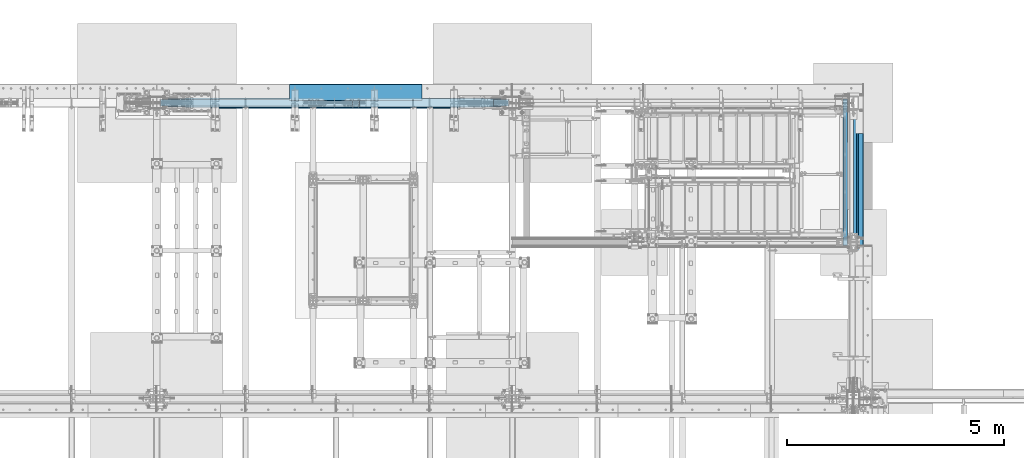
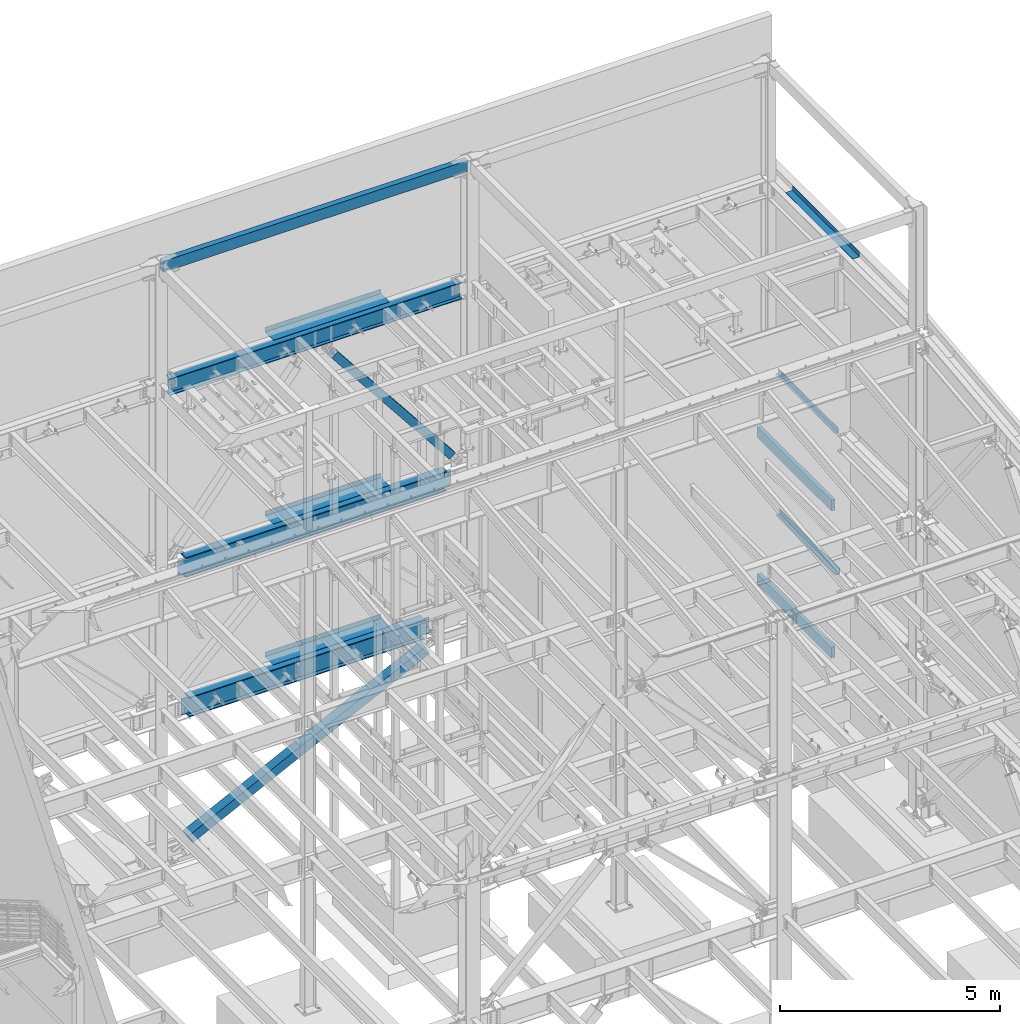
# One storey, part 789 of 1179: 12 beams, 2 members, 11 elements without a shape of their own.
"""IFC2X3 building model written with IfcOpenShell, lengths in millimetres."""

from ifc_helpers import new_model, si_unit, frame, origin_with_axes, place, context, subcontext, project, spatial, faceted_brep, material, type_object, element, aggregate, save


model = new_model("IFC2X3")

# Units and contexts
model_context = context("Model", 3, precision=1e-05, world=origin_with_axes())
body_context = subcontext(model_context, "Body", "Model", "MODEL_VIEW")
ifc_project = project(units=[si_unit("LENGTHUNIT", "METRE", prefix="MILLI"), si_unit("AREAUNIT", "SQUARE_METRE"), si_unit("VOLUMEUNIT", "CUBIC_METRE"), si_unit("MASSUNIT", "GRAM", prefix="KILO"), si_unit("TIMEUNIT", "SECOND"), si_unit("PLANEANGLEUNIT", "RADIAN"), si_unit("SOLIDANGLEUNIT", "STERADIAN"), si_unit("THERMODYNAMICTEMPERATUREUNIT", "DEGREE_CELSIUS"), si_unit("LUMINOUSINTENSITYUNIT", "LUMEN")], contexts=[model_context])

# Site, building, storey
site_placement = place(None, origin_with_axes())
site = spatial("IfcSite", under=ifc_project, at=site_placement, CompositionType="ELEMENT")
building_placement = place(site_placement, origin_with_axes())
building = spatial("IfcBuilding", under=site, at=building_placement, Name="Undefined", CompositionType="ELEMENT")
storey_placement = place(building_placement, origin_with_axes())
storey = spatial("IfcBuildingStorey", under=building, at=storey_placement, Name="Undefined", CompositionType="ELEMENT", Elevation=0.0)

# Assembly, beam
assembly_1_placement = place(storey_placement, origin_with_axes())
assembly_1 = element("IfcElementAssembly", 1, at=assembly_1_placement, inside=storey, Name="BEAM", AssemblyPlace="NOTDEFINED", PredefinedType="RIGID_FRAME")
ifc_material_1 = material(Name="STEEL/A36")
beam_type_1 = type_object("IfcBeamType", PredefinedType="NOTDEFINED")
beam_1_placement = place(assembly_1_placement, frame((24350.663, 38969.95, 13122.275), z_axis=(0.0, -1.0, 0.0), x_axis=(1.0, 0.0, 0.0)))
beam_1 = element("IfcBeam", 2, at=beam_1_placement, type_object=beam_type_1, material=ifc_material_1, Name="BENT_PLATE", context=body_context, shape_type="Brep", body=[
    faceted_brep([(0.0, -3.17499999999927, -1524.0), (6.00266503170133e-10, -3.17499999922438, 1524.00000000052), (6.00266503170133e-10, 3.17500000077416, 1524.00000000052), (0.0, 3.17499999999927, -1524.0), (179.387000203274, 3.1749999978274, 1523.9999999998), (179.387000201926, 3.17499999921893, -1523.99999999987), (185.737000201926, -3.17500000083055, -1523.99999999987), (185.737000203274, -3.17500000222026, 1523.9999999998), (179.387000000002, 130.175000000001, 1524.0), (179.387000000002, 130.175000000001, -1524.0), (185.737000000001, 130.175000000001, 1524.0), (185.737000000001, 130.175000000001, -1524.0)], [[[0, 1, 2, 3]], [[3, 2, 4, 5]], [[1, 0, 6, 7]], [[5, 4, 8, 9]], [[4, 2, 1, 7, 10, 8]], [[7, 6, 11, 10]], [[6, 0, 3, 5, 9, 11]], [[10, 11, 9, 8]]]),
])
aggregate(assembly_1, [beam_1])

assembly_2_placement = place(storey_placement, origin_with_axes())
assembly_2 = element("IfcElementAssembly", 3, at=assembly_2_placement, inside=storey, Name="BEAM", AssemblyPlace="NOTDEFINED", PredefinedType="RIGID_FRAME")
beam_type_2 = type_object("IfcBeamType", PredefinedType="NOTDEFINED")
beam_2_placement = place(assembly_2_placement, frame((12855.575, 41244.838, 13122.275), z_axis=(-1.0, 0.0, 0.0), x_axis=(0.0, 1.0, 0.0)))
beam_2 = element("IfcBeam", 4, at=beam_2_placement, type_object=beam_type_2, material=ifc_material_1, Name="BENT_PLATE", context=body_context, shape_type="Brep", body=[
    faceted_brep([(0.0, -3.17499999999927, -1524.0), (6.00266503170133e-10, -3.17499999922438, 1524.00000000052), (6.00266503170133e-10, 3.17500000077416, 1524.00000000052), (0.0, 3.17499999999927, -1524.0), (385.762000000002, 3.17499999999927, 1524.0), (385.762000000002, 3.17499999999927, -1524.0), (379.411999999997, -3.17499999999927, -1524.0), (379.411999999997, -3.17499999999927, 1524.0), (385.762000000002, -130.175000000001, 1524.0), (385.762000000002, -130.175000000001, -1524.0), (379.411999999997, -130.175000000001, 1524.0), (379.411999999997, -130.175000000001, -1524.0)], [[[0, 1, 2, 3]], [[3, 2, 4, 5]], [[1, 0, 6, 7]], [[5, 4, 8, 9]], [[4, 2, 1, 7, 10, 8]], [[7, 6, 11, 10]], [[6, 0, 3, 5, 9, 11]], [[10, 11, 9, 8]]]),
])

assembly_3_placement = place(storey_placement, origin_with_axes())
assembly_3 = element("IfcElementAssembly", 5, at=assembly_3_placement, inside=storey, Name="BEAM", AssemblyPlace="NOTDEFINED", PredefinedType="RIGID_FRAME")
ifc_material_2 = material()
beam_type_3 = type_object("IfcBeamType", Name="HSS12X4X3/8", PredefinedType="NOTDEFINED")
beam_3_placement = place(assembly_3_placement, frame((24114.125, 37909.5, 6089.65), z_axis=(0.0, 0.0, 1.0), x_axis=(0.0, 1.0, 0.0)))
beam_3 = element("IfcBeam", 6, at=beam_3_placement, type_object=beam_type_3, material=ifc_material_2, Name="BEAM", ObjectType="HSS12X4X3/8", context=body_context, shape_type="Brep", body=[
    faceted_brep([(9.52499999695283, 41.275, -142.875), (9.52499999695283, -41.275, -142.875), (3381.37500000001, -41.2750000000015, -142.875), (3381.37500000001, 41.2750000000015, -142.875), (9.5249993518446, -41.2750000000001, 142.875), (3381.37500000001, -41.2750000000015, 142.875), (9.5249993518446, 41.2750000000001, 142.875), (3381.37500000001, 41.2750000000015, 142.875), (9.52499999695283, 50.8, -152.4), (9.5249993518446, 50.8, 152.4), (3381.37500000001, 50.7999999999993, 152.4), (3381.37500000001, 50.7999999999993, -152.4), (9.5249993518446, -50.8, 152.4), (3381.37500000001, -50.7999999999993, 152.4), (9.52499999695283, -50.8, -152.4), (3381.37500000001, -50.7999999999993, -152.4)], [[[0, 1, 2, 3]], [[1, 4, 5, 2]], [[4, 6, 7, 5]], [[6, 0, 3, 7]], [[8, 9, 10, 11]], [[9, 12, 13, 10]], [[12, 14, 15, 13]], [[14, 8, 11, 15]], [[13, 15, 11, 10], [5, 7, 3, 2]], [[14, 12, 9, 8], [6, 4, 1, 0]]]),
])
aggregate(assembly_3, [beam_3])

assembly_4_placement = place(storey_placement, origin_with_axes())
assembly_4 = element("IfcElementAssembly", 7, at=assembly_4_placement, inside=storey, Name="BEAM", AssemblyPlace="NOTDEFINED", PredefinedType="RIGID_FRAME")
beam_4_placement = place(assembly_4_placement, frame((24114.1250004143, 37909.5, 2003.425), z_axis=(0.0, 0.0, 1.0), x_axis=(0.0, 1.0, 0.0)))
beam_4 = element("IfcBeam", 8, at=beam_4_placement, type_object=beam_type_3, material=ifc_material_2, Name="BEAM", ObjectType="HSS12X4X3/8", context=body_context, shape_type="Brep", body=[
    faceted_brep([(9.52499999695283, 41.275, -142.875), (9.52499999695283, -41.275, -142.875), (3381.37500000001, -41.2750000000015, -142.875), (3381.37500000001, 41.2750000000015, -142.875), (9.5249993518446, -41.2750000000001, 142.875), (3381.37500000001, -41.2750000000015, 142.875), (9.5249993518446, 41.2750000000001, 142.875), (3381.37500000001, 41.2750000000015, 142.875), (9.52499999695283, 50.8, -152.4), (9.5249993518446, 50.8, 152.4), (3381.37500000001, 50.7999999999993, 152.4), (3381.37500000001, 50.7999999999993, -152.4), (9.5249993518446, -50.8, 152.4), (3381.37500000001, -50.7999999999993, 152.4), (9.52499999695283, -50.8, -152.4), (3381.37500000001, -50.7999999999993, -152.4)], [[[0, 1, 2, 3]], [[1, 4, 5, 2]], [[4, 6, 7, 5]], [[6, 0, 3, 7]], [[8, 9, 10, 11]], [[9, 12, 13, 10]], [[12, 14, 15, 13]], [[14, 8, 11, 15]], [[13, 15, 11, 10], [5, 7, 3, 2]], [[14, 12, 9, 8], [6, 4, 1, 0]]]),
])
aggregate(assembly_4, [beam_4])

assembly_5_placement = place(storey_placement, origin_with_axes())
assembly_5 = element("IfcElementAssembly", 9, at=assembly_5_placement, inside=storey, Name="BEAM", AssemblyPlace="NOTDEFINED", PredefinedType="RIGID_FRAME")
beam_type_4 = type_object("IfcBeamType", PredefinedType="NOTDEFINED")
beam_5_placement = place(assembly_5_placement, frame((12855.575, 41627.425, 4235.45000610352), z_axis=(1.0, 0.0, 0.0), x_axis=(0.0, 0.0, -1.0)))
beam_5 = element("IfcBeam", 10, at=beam_5_placement, type_object=beam_type_4, material=ifc_material_1, Name="BENT_PLATE", context=body_context, shape_type="Brep", body=[
    faceted_brep([(0.0, -3.17499999999927, -1524.0), (6.00266503170133e-10, -3.17499999922438, 1524.00000000052), (6.00266503170133e-10, 3.17500000077416, 1524.00000000052), (0.0, 3.17499999999927, -1524.0), (133.350006103513, 3.17500000000291, 1524.0), (133.350006103513, 3.17500000000291, -1524.0), (127.000006103513, -3.17500000000291, -1524.0), (127.000006103513, -3.17500000000291, 1524.0), (133.350006103513, -373.062500000007, 1524.0), (133.350006103513, -373.062500000007, -1524.0), (127.000006103513, -373.062500000007, 1524.0), (127.000006103513, -373.062500000007, -1524.0)], [[[0, 1, 2, 3]], [[3, 2, 4, 5]], [[1, 0, 6, 7]], [[5, 4, 8, 9]], [[4, 2, 1, 7, 10, 8]], [[7, 6, 11, 10]], [[6, 0, 3, 5, 9, 11]], [[10, 11, 9, 8]]]),
])

assembly_6_placement = place(storey_placement, origin_with_axes())
assembly_6 = element("IfcElementAssembly", 11, at=assembly_6_placement, inside=storey, Name="BEAM", AssemblyPlace="NOTDEFINED", PredefinedType="RIGID_FRAME")
beam_6_placement = place(assembly_6_placement, frame((12855.575, 41627.425, 8147.05000610352), z_axis=(1.0, 0.0, 0.0), x_axis=(0.0, 0.0, -1.0)))
beam_6 = element("IfcBeam", 12, at=beam_6_placement, type_object=beam_type_4, material=ifc_material_1, Name="BENT_PLATE", context=body_context, shape_type="Brep", body=[
    faceted_brep([(0.0, -3.17499999999927, -1524.0), (6.00266503170133e-10, -3.17499999922438, 1524.00000000052), (6.00266503170133e-10, 3.17500000077416, 1524.00000000052), (0.0, 3.17499999999927, -1524.0), (133.350006103513, 3.17500000000291, 1524.0), (133.350006103513, 3.17500000000291, -1524.0), (127.000006103513, -3.17500000000291, -1524.0), (127.000006103513, -3.17500000000291, 1524.0), (133.350006103513, -373.062500000007, 1524.0), (133.350006103513, -373.062500000007, -1524.0), (127.000006103513, -373.062500000007, 1524.0), (127.000006103513, -373.062500000007, -1524.0)], [[[0, 1, 2, 3]], [[3, 2, 4, 5]], [[1, 0, 6, 7]], [[5, 4, 8, 9]], [[4, 2, 1, 7, 10, 8]], [[7, 6, 11, 10]], [[6, 0, 3, 5, 9, 11]], [[10, 11, 9, 8]]]),
])

# Assembly, member
assembly_7_placement = place(storey_placement, origin_with_axes())
assembly_7 = element("IfcElementAssembly", 13, at=assembly_7_placement, inside=storey, Name="None", AssemblyPlace="NOTDEFINED", PredefinedType="RIGID_FRAME")
ifc_material_3 = material(Name="STEEL/A992")
member_type_1 = type_object("IfcMemberType", Name="HSS8X8X3/16", PredefinedType="NOTDEFINED")
member_1_placement = place(assembly_7_placement, frame((15948.6124361633, 41198.8, 8381.65756256615), z_axis=(0.0, 1.0, 0.0), x_axis=(-0.622099916714249, 0.0, 0.782937860640373)))
member_1 = element("IfcMember", 14, at=member_1_placement, type_object=member_type_1, material=ifc_material_3, Name="None", ObjectType="HSS8X8X3/16", context=body_context, shape_type="Brep", body=[
    faceted_brep([(-3.63797880709171e-12, 96.8374999999978, -96.8375000000015), (-3.63797880709171e-12, -96.8374999999978, -96.8375000000015), (4965.25424181688, -96.8375000011438, -96.8375000000015), (4965.25424181692, 96.8374999988555, -96.8375000000015), (-3.63797880709171e-12, -96.8374999999978, 96.8375000000015), (4965.25424181688, -96.8375000011438, 96.8375000000015), (-3.63797880709171e-12, 96.8374999999978, 96.8375000000015), (4965.25424181692, 96.8374999988555, 96.8375000000015), (-3.63797880709171e-12, 101.599999999999, -101.599999999999), (-3.63797880709171e-12, 101.599999999999, 101.599999999999), (4965.25424181692, 101.599999998856, 101.599999999999), (4965.25424181692, 101.599999998856, -101.599999999999), (0.0, -101.599999999999, 101.599999999999), (4965.25424181688, -101.600000001145, 101.599999999999), (0.0, -101.599999999999, -101.599999999999), (4965.25424181688, -101.600000001145, -101.599999999999)], [[[0, 1, 2, 3]], [[1, 4, 5, 2]], [[4, 6, 7, 5]], [[6, 0, 3, 7]], [[8, 9, 10, 11]], [[9, 12, 13, 10]], [[12, 14, 15, 13]], [[14, 8, 11, 15]], [[13, 15, 11, 10], [5, 7, 3, 2]], [[14, 12, 9, 8], [6, 4, 1, 0]]]),
])
aggregate(assembly_7, [member_1])

# Assembly, beam
assembly_8_placement = place(storey_placement, origin_with_axes())
assembly_8 = element("IfcElementAssembly", 15, at=assembly_8_placement, inside=storey, Name="BEAM", AssemblyPlace="NOTDEFINED", PredefinedType="RIGID_FRAME")
beam_type_5 = type_object("IfcBeamType", PredefinedType="NOTDEFINED")
beam_7_placement = place(assembly_8_placement, frame((24313.3562411367, 39530.3375121841, 3933.82500614811), z_axis=(0.0, 1.0, 0.0), x_axis=(1.0, 0.0, 0.0)))
beam_7 = element("IfcBeam", 16, at=beam_7_placement, type_object=beam_type_5, material=ifc_material_1, Name="BENT_PLATE", context=body_context, shape_type="Brep", body=[
    faceted_brep([(-2.1500454749912e-09, -3.17500000000109, -1373.18749999999), (1.74986780621111e-09, -3.17500000000109, 1373.18750000001), (2.15732143260539e-09, 3.17499999999927, 1373.18750000001), (-1.74259184859693e-09, 3.17499999999927, -1373.18749999999), (111.91875218078, 3.17499999289703, 1373.18749999985), (111.91875217688, 3.17499999289703, -1373.18750000015), (105.568751827632, -3.17500000670043, -1373.18750000015), (105.568751831532, -3.17500000670043, 1373.18749999985), (111.91874379884, -149.224999817552, 1373.18749999985), (111.91874379494, -149.224999817552, -1373.18750000015), (105.568743798842, -149.224999468311, 1373.18749999985), (105.568743794942, -149.224999468311, -1373.18750000015)], [[[0, 1, 2, 3]], [[3, 2, 4, 5]], [[1, 0, 6, 7]], [[5, 4, 8, 9]], [[4, 2, 1, 7, 10, 8]], [[7, 6, 11, 10]], [[6, 0, 3, 5, 9, 11]], [[10, 11, 9, 8]]]),
])
aggregate(assembly_8, [beam_7])

assembly_9_placement = place(storey_placement, origin_with_axes())
assembly_9 = element("IfcElementAssembly", 17, at=assembly_9_placement, inside=storey, Name="BEAM", AssemblyPlace="NOTDEFINED", PredefinedType="RIGID_FRAME")
beam_type_6 = type_object("IfcBeamType", PredefinedType="NOTDEFINED")
beam_8_placement = place(assembly_9_placement, frame((24313.3562373621, 39530.3375121841, 7847.01250614851), z_axis=(0.0, 1.0, 0.0), x_axis=(1.0, 0.0, 0.0)))
beam_8 = element("IfcBeam", 18, at=beam_8_placement, type_object=beam_type_6, material=ifc_material_1, Name="BENT_PLATE", context=body_context, shape_type="Brep", body=[
    faceted_brep([(-2.1500454749912e-09, -3.17500000000109, -1373.18749999999), (1.74986780621111e-09, -3.17500000000109, 1373.18750000001), (2.15732143260539e-09, 3.17499999999927, 1373.18750000001), (-1.74259184859693e-09, 3.17499999999927, -1373.18749999999), (72.2312532168035, 3.17500000845757, 1373.18750000041), (72.2312532244323, 3.17500000845757, -1373.18749999959), (65.8812526846959, -3.17499999228585, -1373.18749999963), (65.8812526770671, -3.17499999228585, 1373.18750000037), (72.2312402643402, -149.22500006254, 1373.18750000054), (72.2312402694442, -149.225000065037, -1373.18749999946), (65.881240264338, -149.22499952279, 1373.18750000051), (65.8812402694457, -149.224999525288, -1373.18749999949)], [[[0, 1, 2, 3]], [[3, 2, 4, 5]], [[1, 0, 6, 7]], [[5, 4, 8, 9]], [[4, 2, 1, 7, 10, 8]], [[7, 6, 11, 10]], [[6, 0, 3, 5, 9, 11]], [[10, 11, 9, 8]]]),
])
aggregate(assembly_9, [beam_8])

# Assembly, member
assembly_10_placement = place(storey_placement, origin_with_axes())
assembly_10 = element("IfcElementAssembly", 19, at=assembly_10_placement, inside=storey, Name="None", AssemblyPlace="NOTDEFINED", PredefinedType="RIGID_FRAME")
member_type_2 = type_object("IfcMemberType", Name="HSS10X10X1/4", PredefinedType="NOTDEFINED")
member_2_placement = place(assembly_10_placement, frame((9054.05970095868, 41198.8, 166.575011340778), z_axis=(0.0, -1.0, 0.0), x_axis=(0.896436455583732, 0.0, 0.443172292794209)))
member_2 = element("IfcMember", 20, at=member_2_placement, type_object=member_type_2, material=ifc_material_3, Name="None", ObjectType="HSS10X10X1/4", context=body_context, shape_type="Brep", body=[
    faceted_brep([(-6.09361450187862e-11, 120.650000000031, -120.650000000001), (6.00266503170133e-11, -120.650000000031, -120.650000000001), (6950.07499997456, -120.649999998347, -120.650000000001), (6950.07499997444, 120.650000001714, -120.650000000001), (6.00266503170133e-11, -120.650000000031, 120.650000000001), (6950.07499997456, -120.649999998347, 120.650000000001), (-6.09361450187862e-11, 120.650000000031, 120.650000000001), (6950.07499997444, 120.650000001714, 120.650000000001), (-6.3664629124105e-11, 127.000000000032, -127.0), (-6.3664629124105e-11, 127.000000000032, 127.0), (6950.07499997444, 127.000000001715, 127.0), (6950.07499997444, 127.000000001715, -127.0), (6.2755134422332e-11, -127.000000000033, 127.0), (6950.07499997456, -126.99999999835, 127.0), (6.2755134422332e-11, -127.000000000033, -127.0), (6950.07499997456, -126.99999999835, -127.0)], [[[0, 1, 2, 3]], [[1, 4, 5, 2]], [[4, 6, 7, 5]], [[6, 0, 3, 7]], [[8, 9, 10, 11]], [[9, 12, 13, 10]], [[12, 14, 15, 13]], [[14, 8, 11, 15]], [[13, 15, 11, 10], [5, 7, 3, 2]], [[14, 12, 9, 8], [6, 4, 1, 0]]]),
])
aggregate(assembly_10, [member_2])

# Assembly, beam
assembly_11_placement = place(storey_placement, origin_with_axes())
assembly_11 = element("IfcElementAssembly", 21, at=assembly_11_placement, inside=storey, Name="BEAM", AssemblyPlace="NOTDEFINED", PredefinedType="RIGID_FRAME")
beam_type_7 = type_object("IfcBeamType", Name="HSS12X6X3/8", PredefinedType="NOTDEFINED")
beam_9_placement = place(assembly_11_placement, frame((8358.18750000001, 41198.8, 16275.05), z_axis=(0.0, 0.0, 1.0), x_axis=(1.0, 0.0, 0.0)))
beam_9 = element("IfcBeam", 22, at=beam_9_placement, type_object=beam_type_7, material=ifc_material_2, Name="BEAM", ObjectType="HSS12X6X3/8", context=body_context, shape_type="Brep", body=[
    faceted_brep([(9.52500000000146, 66.675, -142.875), (9.52500000000146, -66.675, -142.875), (8013.69999995936, -66.6750000000029, -142.875), (8013.69999995936, 66.6750000000029, -142.875), (9.52500000000146, -66.675, 142.875000000002), (8013.69999995936, -66.6750000000029, 142.875000000002), (9.52500000000146, 66.675, 142.875000000002), (8013.69999995936, 66.6750000000029, 142.875000000002), (9.52500000000146, 76.2, -152.4), (9.52500000000146, 76.2, 152.4), (8013.69999995936, 76.1999999999971, 152.4), (8013.69999995936, 76.1999999999971, -152.4), (9.52500000000146, -76.2, 152.4), (8013.69999995936, -76.1999999999971, 152.4), (9.52500000000146, -76.2, -152.4), (8013.69999995936, -76.1999999999971, -152.4)], [[[0, 1, 2, 3]], [[1, 4, 5, 2]], [[4, 6, 7, 5]], [[6, 0, 3, 7]], [[8, 9, 10, 11]], [[9, 12, 13, 10]], [[12, 14, 15, 13]], [[14, 8, 11, 15]], [[13, 15, 11, 10], [5, 7, 3, 2]], [[14, 12, 9, 8], [6, 4, 1, 0]]]),
])
aggregate(assembly_11, [beam_9])

# Beam
beam_type_8 = type_object("IfcBeamType", Name="W18X65", PredefinedType="NOTDEFINED")
beam_10_placement = place(assembly_2_placement, frame((8280.4, 41198.8, 12885.7375), z_axis=(0.0, 0.0, 1.0), x_axis=(1.0, 0.0, 0.0)))
beam_10 = element("IfcBeam", 23, at=beam_10_placement, type_object=beam_type_8, material=ifc_material_3, Name="BEAM", ObjectType="W18X65", context=body_context, shape_type="Brep", body=[
    faceted_brep([(260.349999999999, -96.8375000000015, -233.362499999999), (260.349999999999, 96.8375000000015, -233.362499999999), (7918.45, 96.8375000000015, -233.362499999999), (7918.45, -96.8375000000015, -233.362499999999), (260.349999999999, -96.8375000000015, -214.3125), (260.349999999999, -5.55625000000146, -214.3125), (260.349999999999, -5.55625000000146, -122.977499999975), (260.349999999999, -5.55625000000146, 183.302500000125), (260.349999999999, -5.55625000000146, 214.3125), (260.349999999999, -96.8375000000015, 214.3125), (260.349999999999, -96.8375000000015, 233.362499999999), (260.349999999999, 96.8375000000015, 233.362499999999), (260.349999999999, 96.8375000000015, 214.3125), (260.349999999999, 5.55625000000146, 214.3125), (260.349999999999, 5.55625000000146, -214.3125), (260.349999999999, 96.8375000000015, -214.3125), (7918.45, -96.8375000000015, -214.3125), (7918.45, -5.55625000000146, -214.3125), (7918.45, -5.55625000000146, -122.977499999979), (7918.45, -5.55625000000146, 183.302500000125), (7918.45, -5.55625000000146, 214.3125), (7918.45, -96.8375000000015, 214.3125), (7918.45, -96.8375000000015, 233.362499999999), (7918.45, 96.8375000000015, 233.362499999999), (7918.45, 96.8375000000015, 214.3125), (7918.45, 5.55625000000146, 214.3125), (7918.45, 5.55625000000146, -214.3125), (7918.45, 96.8375000000015, -214.3125)], [[[0, 1, 2, 3]], [[0, 4, 5, 6, 7, 8, 9, 10, 11, 12, 13, 14, 15, 1]], [[5, 4, 16, 17]], [[8, 7, 6, 5, 17, 18, 19, 20]], [[9, 8, 20, 21]], [[10, 9, 21, 22]], [[11, 10, 22, 23]], [[12, 11, 23, 24]], [[13, 12, 24, 25]], [[14, 13, 25, 26]], [[15, 14, 26, 27]], [[1, 15, 27, 2]], [[26, 25, 24, 23, 22, 21, 20, 19, 18, 17, 16, 3, 2, 27]], [[4, 0, 3, 16]]]),
])

aggregate(assembly_2, [beam_2, beam_10])

beam_type_9 = type_object("IfcBeamType", Name="W21X93", PredefinedType="NOTDEFINED")
beam_11_placement = place(assembly_6_placement, frame((8280.4, 41198.8, 7739.0625), z_axis=(0.0, 0.0, 1.0), x_axis=(1.0, 0.0, 0.0)))
beam_11 = element("IfcBeam", 24, at=beam_11_placement, type_object=beam_type_9, material=ifc_material_3, Name="BEAM", ObjectType="W21X93", context=body_context, shape_type="Brep", body=[
    faceted_brep([(7527.62858333016, -106.362500000003, 250.825), (7527.62858333016, -7.14375000000291, 250.825), (7527.85779811715, -7.14375000000291, 250.428), (7527.85779811715, 7.14375000000291, 250.428), (7527.62858333016, 7.14375000000291, 250.825), (7527.62858333016, 106.362500000003, 250.825), (7513.88002636441, 106.362500000003, 274.6375), (7513.88002636441, -106.362500000003, 274.6375), (664.919985427414, -106.362500000003, -250.825), (651.171818560621, -106.362500000003, -274.6375), (7527.62818022381, -106.362500000003, -274.6375), (7513.88001335702, -106.362500000003, -250.825), (651.171818560621, 106.362500000003, -274.6375), (7527.62818022381, 106.362500000003, -274.6375), (664.919985427414, 106.362500000003, -250.825), (7513.88001335702, 106.362500000003, -250.825), (664.919985427414, 7.14375000000291, -250.825), (7513.88001335702, 7.14375000000291, -250.825), (7470.18923259341, -7.14375000000291, 243.568356973128), (7470.18923259341, 7.14375000000291, 243.568356973128), (7484.76559679041, 7.14375000000291, 250.428), (7484.76559679041, -7.14375000000291, 250.428), (7466.33348398436, -7.14375000000291, 240.254052423033), (7466.33348398436, 7.14375000000291, 240.254052423033), (7464.73205750961, -7.14375000000291, 235.428407882362), (7464.73205750961, 7.14375000000291, 235.428407882362), (7465.84126459035, -7.14375000000291, 230.466445403767), (7465.84126459035, 7.14375000000291, 230.466445403767), (7469.34504709503, -7.14375000000291, 226.782029554974), (7469.34504709503, 7.14375000000291, 226.782029554974), (7474.24503513316, -7.14375000000291, 225.425), (7474.24503513316, 7.14375000000291, 225.425), (7676.85359679041, -7.14375000000291, 225.425), (7676.85359679041, 7.14375000000291, 225.425), (7676.85359679041, -7.14375000000291, -225.425), (7676.85359679041, 7.14375000000291, -225.425), (7471.15103513316, -7.14375000000291, -225.425), (7471.15103513316, 7.14375000000291, -225.425), (7466.25104709503, -7.14375000000291, -226.782029554975), (7466.25104709503, 7.14375000000291, -226.782029554975), (7462.74726459035, -7.14375000000291, -230.466445403767), (7462.74726459035, 7.14375000000291, -230.466445403767), (7461.63805750961, -7.14375000000291, -235.428407882363), (7461.63805750961, 7.14375000000291, -235.428407882363), (7463.23948398436, -7.14375000000291, -240.254052423033), (7463.23948398436, 7.14375000000291, -240.254052423033), (7467.09523259341, -7.14375000000291, -243.568356973128), (7467.09523259341, 7.14375000000291, -243.568356973128), (7481.67159679041, -7.14375000000291, -250.428), (7481.67159679041, 7.14375000000291, -250.428), (7513.65080507372, -7.14375000000291, -250.428), (7513.65080507372, 7.14375000000291, -250.428), (7513.88001335702, -7.14375000000291, -250.825), (664.919985427414, -7.14375000000291, -250.825), (665.149193710717, -7.14375000000291, -250.428), (665.149193710717, 7.14375000000291, -250.428), (697.128401994018, -7.14375000000291, -250.428), (697.128401994018, 7.14375000000291, -250.428), (711.704766191022, -7.14375000000291, -243.568356973128), (711.704766191022, 7.14375000000291, -243.568356973128), (715.560514800069, -7.14375000000291, -240.254052423033), (715.560514800069, 7.14375000000291, -240.254052423033), (717.161941274817, -7.14375000000291, -235.428407882363), (717.161941274817, 7.14375000000291, -235.428407882363), (716.052734194085, -7.14375000000291, -230.466445403767), (716.052734194085, 7.14375000000291, -230.466445403767), (712.548951689405, -7.14375000000291, -226.782029554975), (712.548951689405, 7.14375000000291, -226.782029554975), (707.648963651271, -7.14375000000291, -225.425), (707.648963651271, 7.14375000000291, -225.425), (501.946401994019, -7.14375000000291, -225.425), (501.946401994019, 7.14375000000291, -225.425), (501.946401994019, -7.14375000000291, 225.425), (501.946401994019, 7.14375000000291, 225.425), (704.554963651271, -7.14375000000291, 225.425), (704.554963651271, 7.14375000000291, 225.425), (709.454951689404, -7.14375000000291, 226.782029554974), (709.454951689404, 7.14375000000291, 226.782029554974), (712.958734194084, -7.14375000000291, 230.466445403767), (712.958734194084, 7.14375000000291, 230.466445403767), (714.067941274818, -7.14375000000291, 235.428407882362), (714.067941274818, 7.14375000000291, 235.428407882362), (712.466514800068, -7.14375000000291, 240.254052423033), (712.466514800068, 7.14375000000291, 240.254052423033), (708.610766191023, -7.14375000000291, 243.568356973128), (708.610766191023, 7.14375000000291, 243.568356973128), (694.034401994018, -7.14375000000291, 250.428), (694.034401994018, 7.14375000000291, 250.428), (650.942200667279, -7.14375000000291, 250.428), (650.942200667279, 7.14375000000291, 250.428), (664.919972420021, -106.362500000003, 274.6375), (664.919972420021, 106.362500000003, 274.6375), (651.171415454281, 106.362500000003, 250.825), (651.171415454281, 7.14375000000291, 250.825), (651.171415454281, -7.14375000000291, 250.825), (651.171415454281, -106.362500000003, 250.825)], [[[0, 1, 2, 3, 4, 5, 6, 7]], [[8, 9, 10, 11]], [[9, 12, 13, 10]], [[12, 14, 15, 13]], [[14, 16, 17, 15]], [[18, 19, 20, 21]], [[22, 23, 19, 18]], [[24, 25, 23, 22]], [[26, 27, 25, 24]], [[28, 29, 27, 26]], [[30, 31, 29, 28]], [[31, 30, 32, 33]], [[32, 34, 35, 33]], [[36, 37, 35, 34]], [[38, 39, 37, 36]], [[40, 41, 39, 38]], [[42, 43, 41, 40]], [[44, 45, 43, 42]], [[46, 47, 45, 44]], [[48, 49, 47, 46]], [[49, 48, 50, 51]], [[10, 13, 15, 17, 51, 50, 52, 11]], [[53, 8, 11, 52]], [[54, 55, 16, 14, 12, 9, 8, 53]], [[56, 57, 55, 54]], [[58, 59, 57, 56]], [[60, 61, 59, 58]], [[62, 63, 61, 60]], [[64, 65, 63, 62]], [[66, 67, 65, 64]], [[68, 69, 67, 66]], [[69, 68, 70, 71]], [[72, 73, 71, 70]], [[74, 75, 73, 72]], [[76, 77, 75, 74]], [[78, 79, 77, 76]], [[80, 81, 79, 78]], [[82, 83, 81, 80]], [[84, 85, 83, 82]], [[86, 87, 85, 84]], [[87, 86, 88, 89]], [[90, 91, 92, 93, 89, 88, 94, 95]], [[90, 95, 0, 7]], [[91, 90, 7, 6]], [[92, 91, 6, 5]], [[93, 92, 5, 4]], [[20, 19, 23, 25, 27, 29, 31, 33, 35, 37, 39, 41, 43, 45, 47, 49, 51, 17, 16, 55, 57, 59, 61, 63, 65, 67, 69, 71, 73, 75, 77, 79, 81, 83, 85, 87, 89, 93, 4, 3]], [[21, 20, 3, 2]], [[94, 88, 86, 84, 82, 80, 78, 76, 74, 72, 70, 68, 66, 64, 62, 60, 58, 56, 54, 53, 52, 50, 48, 46, 44, 42, 40, 38, 36, 34, 32, 30, 28, 26, 24, 22, 18, 21, 2, 1]], [[95, 94, 1, 0]]]),
])

aggregate(assembly_6, [beam_6, beam_11])

beam_12_placement = place(assembly_5_placement, frame((8280.4, 41198.8, 3827.4625), z_axis=(0.0, 0.0, 1.0), x_axis=(1.0, 0.0, 0.0)))
beam_12 = element("IfcBeam", 25, at=beam_12_placement, type_object=beam_type_9, material=ifc_material_3, Name="BEAM", ObjectType="W21X93", context=body_context, shape_type="Brep", body=[
    faceted_brep([(6952.94178666081, -106.362500000003, 250.825), (6952.94178666081, -7.14375000000291, 250.825), (6953.17100144781, -7.14375000000291, 250.428), (6953.17100144781, 7.14375000000291, 250.428), (6952.94178666081, 7.14375000000291, 250.825), (6952.94178666081, 106.362500000003, 250.825), (6939.19322969507, 106.362500000003, 274.6375), (6939.19322969507, -106.362500000003, 274.6375), (765.163109525665, -106.362500000003, -250.825), (751.414942658872, -106.362500000003, -274.6375), (6952.94138355447, -106.362500000003, -274.6375), (6939.19321668768, -106.362500000003, -250.825), (751.414942658872, 106.362500000003, -274.6375), (6952.94138355447, 106.362500000003, -274.6375), (765.163109525665, 106.362500000003, -250.825), (6939.19321668768, 106.362500000003, -250.825), (765.163109525665, 7.14375000000291, -250.825), (6939.19321668768, 7.14375000000291, -250.825), (6882.27922320801, -7.14375000000291, 243.923533666101), (6882.27922320801, 7.14375000000291, 243.923533666101), (6900.55380012108, 7.14375000000291, 250.428), (6900.55380012108, -7.14375000000291, 250.428), (6878.00088442569, -7.14375000000291, 240.856821654457), (6878.00088442569, 7.14375000000291, 240.856821654457), (6876.00468926065, -7.14375000000291, 235.986081447698), (6876.00468926065, 7.14375000000291, 235.986081447698), (6876.90030435576, -7.14375000000291, 230.798906985616), (6876.90030435576, 7.14375000000291, 230.798906985616), (6880.41419601156, -7.14375000000291, 226.879535769469), (6880.41419601156, 7.14375000000291, 226.879535769469), (6885.47317130247, -7.14375000000291, 225.425), (6885.47317130247, 7.14375000000291, 225.425), (7102.16680012107, -7.14375000000291, 225.425), (7102.16680012107, 7.14375000000291, 225.425), (7102.16680012107, -7.14375000000291, -225.425), (7102.16680012107, 7.14375000000291, -225.425), (6885.55417130247, -7.14375000000291, -225.425), (6885.55417130247, 7.14375000000291, -225.425), (6880.49519601156, -7.14375000000291, -226.87953576947), (6880.49519601156, 7.14375000000291, -226.87953576947), (6876.98130435576, -7.14375000000291, -230.798906985616), (6876.98130435576, 7.14375000000291, -230.798906985616), (6876.08568926065, -7.14375000000291, -235.986081447699), (6876.08568926065, 7.14375000000291, -235.986081447699), (6878.08188442569, -7.14375000000291, -240.856821654458), (6878.08188442569, 7.14375000000291, -240.856821654458), (6882.36022320801, -7.14375000000291, -243.923533666101), (6882.36022320801, 7.14375000000291, -243.923533666101), (6900.63480012108, -7.14375000000291, -250.428), (6900.63480012108, 7.14375000000291, -250.428), (6938.96400840438, -7.14375000000291, -250.428), (6938.96400840438, 7.14375000000291, -250.428), (6939.19321668768, -7.14375000000291, -250.825), (765.163109525665, -7.14375000000291, -250.825), (765.392317808966, -7.14375000000291, -250.428000000001), (765.392317808966, 7.14375000000291, -250.428000000001), (803.721526092269, -7.14375000000291, -250.428000000001), (803.721526092269, 7.14375000000291, -250.428000000001), (821.996103005338, -7.14375000000291, -243.923533666101), (821.996103005338, 7.14375000000291, -243.923533666101), (826.274441787658, -7.14375000000291, -240.856821654457), (826.274441787658, 7.14375000000291, -240.856821654457), (828.270636952699, -7.14375000000291, -235.986081447698), (828.270636952699, 7.14375000000291, -235.986081447698), (827.375021857588, -7.14375000000291, -230.798906985616), (827.375021857588, 7.14375000000291, -230.798906985616), (823.861130201785, -7.14375000000291, -226.87953576947), (823.861130201785, 7.14375000000291, -226.87953576947), (818.80215491088, -7.14375000000291, -225.425), (818.80215491088, 7.14375000000291, -225.425), (602.18952609227, -7.14375000000291, -225.425), (602.18952609227, 7.14375000000291, -225.425), (602.18952609227, -7.14375000000291, 225.425), (602.18952609227, 7.14375000000291, 225.425), (818.883154910876, -7.14375000000291, 225.425), (818.883154910876, 7.14375000000291, 225.425), (823.942130201785, -7.14375000000291, 226.879535769468), (823.942130201785, 7.14375000000291, 226.879535769468), (827.456021857586, -7.14375000000291, 230.798906985615), (827.456021857586, 7.14375000000291, 230.798906985615), (828.351636952697, -7.14375000000291, 235.986081447697), (828.351636952697, 7.14375000000291, 235.986081447697), (826.355441787657, -7.14375000000291, 240.856821654456), (826.355441787657, 7.14375000000291, 240.856821654456), (822.077103005335, -7.14375000000291, 243.923533666101), (822.077103005335, 7.14375000000291, 243.923533666101), (803.80252609227, -7.14375000000291, 250.427999999999), (803.80252609227, 7.14375000000291, 250.427999999999), (751.185324765529, -7.14375000000291, 250.427999999999), (751.185324765529, 7.14375000000291, 250.427999999999), (765.163096518272, -106.362500000003, 274.6375), (765.163096518272, 106.362500000003, 274.6375), (751.414539552528, 106.362500000003, 250.825), (751.414539552528, 7.14375000000291, 250.825), (751.414539552528, -7.14375000000291, 250.825), (751.414539552528, -106.362500000003, 250.825)], [[[0, 1, 2, 3, 4, 5, 6, 7]], [[8, 9, 10, 11]], [[9, 12, 13, 10]], [[12, 14, 15, 13]], [[14, 16, 17, 15]], [[18, 19, 20, 21]], [[22, 23, 19, 18]], [[24, 25, 23, 22]], [[26, 27, 25, 24]], [[28, 29, 27, 26]], [[30, 31, 29, 28]], [[31, 30, 32, 33]], [[32, 34, 35, 33]], [[36, 37, 35, 34]], [[38, 39, 37, 36]], [[40, 41, 39, 38]], [[42, 43, 41, 40]], [[44, 45, 43, 42]], [[46, 47, 45, 44]], [[48, 49, 47, 46]], [[49, 48, 50, 51]], [[10, 13, 15, 17, 51, 50, 52, 11]], [[53, 8, 11, 52]], [[54, 55, 16, 14, 12, 9, 8, 53]], [[56, 57, 55, 54]], [[58, 59, 57, 56]], [[60, 61, 59, 58]], [[62, 63, 61, 60]], [[64, 65, 63, 62]], [[66, 67, 65, 64]], [[68, 69, 67, 66]], [[69, 68, 70, 71]], [[72, 73, 71, 70]], [[74, 75, 73, 72]], [[76, 77, 75, 74]], [[78, 79, 77, 76]], [[80, 81, 79, 78]], [[82, 83, 81, 80]], [[84, 85, 83, 82]], [[86, 87, 85, 84]], [[87, 86, 88, 89]], [[90, 91, 92, 93, 89, 88, 94, 95]], [[90, 95, 0, 7]], [[91, 90, 7, 6]], [[92, 91, 6, 5]], [[93, 92, 5, 4]], [[20, 19, 23, 25, 27, 29, 31, 33, 35, 37, 39, 41, 43, 45, 47, 49, 51, 17, 16, 55, 57, 59, 61, 63, 65, 67, 69, 71, 73, 75, 77, 79, 81, 83, 85, 87, 89, 93, 4, 3]], [[21, 20, 3, 2]], [[94, 88, 86, 84, 82, 80, 78, 76, 74, 72, 70, 68, 66, 64, 62, 60, 58, 56, 54, 53, 52, 50, 48, 46, 44, 42, 40, 38, 36, 34, 32, 30, 28, 26, 24, 22, 18, 21, 2, 1]], [[95, 94, 1, 0]]]),
])

aggregate(assembly_5, [beam_5, beam_12])

save(model, "model.ifc")
